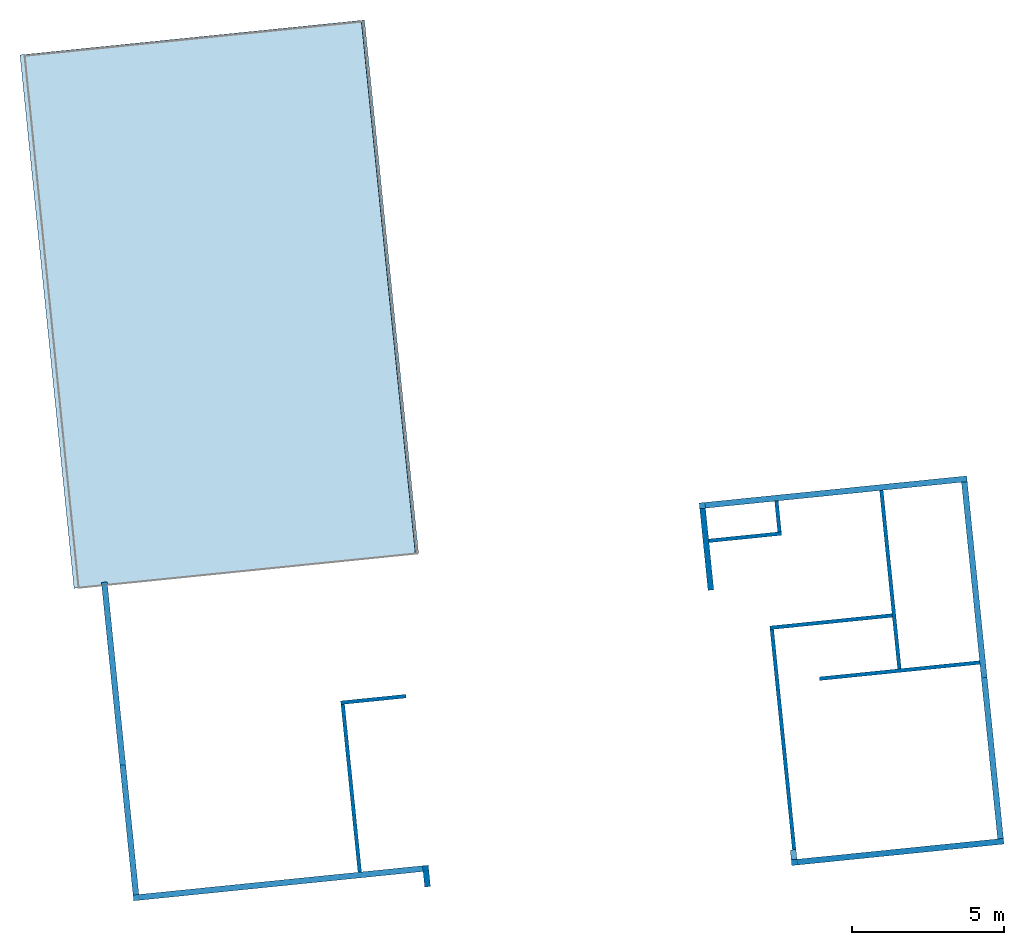
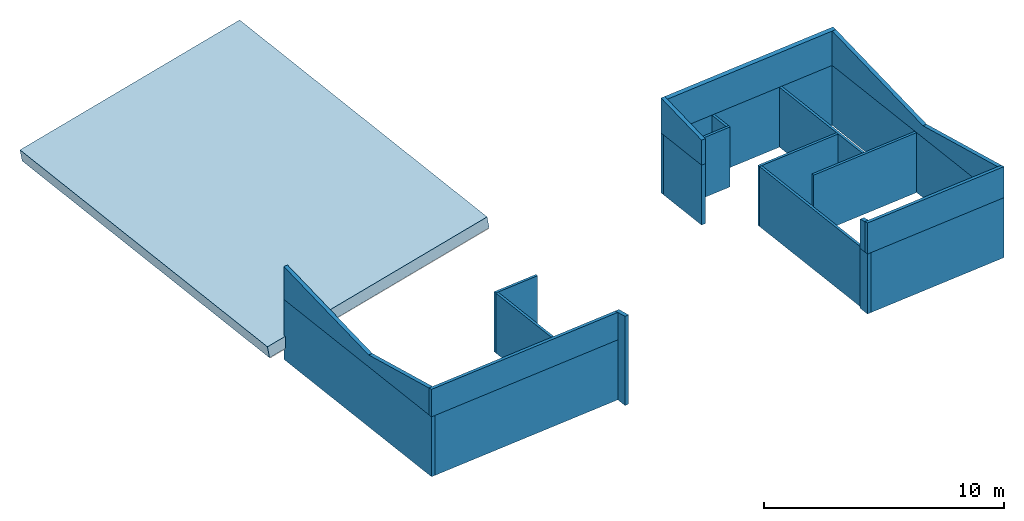
# One storey, part 1 of 2: 23 walls, 1 slab, 1 element without a shape of its own.
"""IFC2X3 building model written with IfcOpenShell, lengths in feet."""

from ifc_helpers import new_model, entity, si_unit, converted_unit, derived_unit, direction, frame, frame_2d, origin, place, context, subcontext, project, spatial, polyline, rectangle, extrude, clip, bounded_halfspace, material, layer, layer_set, layer_usage, type_object, element, aggregate, save


model = new_model("IFC2X3")

# Units and contexts
model_context = context("Model", 3, precision=0.0001, world=origin(), true_north=direction((0.100810849702482, 0.994905609885814)))
body_context = subcontext(model_context, "Body", "Model", "MODEL_VIEW")
ifc_project = project(units=[converted_unit("LENGTHUNIT", "FOOT", entity("IfcRatioMeasure", 0.3048), si_unit("LENGTHUNIT", "METRE"), dimensions=[1, 0, 0, 0, 0, 0, 0]), converted_unit("AREAUNIT", "SQUARE FOOT", entity("IfcRatioMeasure", 0.09290304), si_unit("AREAUNIT", "SQUARE_METRE"), dimensions=[2, 0, 0, 0, 0, 0, 0]), converted_unit("VOLUMEUNIT", "CUBIC FOOT", entity("IfcRatioMeasure", 0.028316846592), si_unit("VOLUMEUNIT", "CUBIC_METRE"), dimensions=[3, 0, 0, 0, 0, 0, 0]), converted_unit("PLANEANGLEUNIT", "DEGREE", entity("IfcRatioMeasure", 0.0174532925199433), si_unit("PLANEANGLEUNIT", "RADIAN"), dimensions=[0, 0, 0, 0, 0, 0, 0]), si_unit("MASSUNIT", "GRAM", prefix="KILO"), derived_unit("MASSDENSITYUNIT", [(si_unit("MASSUNIT", "GRAM", prefix="KILO"), 1), (si_unit("LENGTHUNIT", "METRE"), -3)]), si_unit("TIMEUNIT", "SECOND"), si_unit("FREQUENCYUNIT", "HERTZ"), si_unit("THERMODYNAMICTEMPERATUREUNIT", "DEGREE_CELSIUS"), derived_unit("THERMALTRANSMITTANCEUNIT", [(si_unit("MASSUNIT", "GRAM", prefix="KILO"), 1), (si_unit("THERMODYNAMICTEMPERATUREUNIT", "KELVIN"), -1), (si_unit("TIMEUNIT", "SECOND"), -3)]), derived_unit("VOLUMETRICFLOWRATEUNIT", [(si_unit("LENGTHUNIT", "METRE"), 3), (si_unit("TIMEUNIT", "SECOND"), -1)]), si_unit("ELECTRICCURRENTUNIT", "AMPERE"), si_unit("ELECTRICVOLTAGEUNIT", "VOLT"), si_unit("POWERUNIT", "WATT"), si_unit("FORCEUNIT", "NEWTON"), si_unit("ILLUMINANCEUNIT", "LUX"), si_unit("LUMINOUSFLUXUNIT", "LUMEN"), si_unit("LUMINOUSINTENSITYUNIT", "CANDELA"), derived_unit("USERDEFINED", [(si_unit("MASSUNIT", "GRAM", prefix="KILO"), -1), (si_unit("LENGTHUNIT", "METRE"), -2), (si_unit("TIMEUNIT", "SECOND"), 3), (si_unit("LUMINOUSFLUXUNIT", "LUMEN"), 1)]), derived_unit("LINEARVELOCITYUNIT", [(si_unit("LENGTHUNIT", "METRE"), 1), (si_unit("TIMEUNIT", "SECOND"), -1)]), si_unit("PRESSUREUNIT", "PASCAL"), derived_unit("USERDEFINED", [(si_unit("LENGTHUNIT", "METRE"), -2), (si_unit("MASSUNIT", "GRAM", prefix="KILO"), 1), (si_unit("TIMEUNIT", "SECOND"), -2)])], contexts=[model_context])

# Site, building, storey
site_placement = place(None, frame((124.447249452883, 13.3868691254093, 0.0), z_axis=(0.0, 0.0, 1.0), x_axis=(0.994905609885814, 0.100810849702482, 0.0)))
site = spatial("IfcSite", under=ifc_project, at=site_placement, CompositionType="ELEMENT")
building_placement = place(site_placement, origin())
building = spatial("IfcBuilding", under=site, at=building_placement, CompositionType="ELEMENT")
storey_placement = place(building_placement, frame((0.0, 0.0, 12.0)))
storey = spatial("IfcBuildingStorey", under=building, at=storey_placement, Name="Second Floor", CompositionType="ELEMENT", Elevation=12.0)

# Roof, slab
ifc_material_1 = material(Name="Default Roof")
roof_placement = place(storey_placement, origin())
roof = element("IfcRoof", 1, at=roof_placement, inside=storey, material=ifc_material_1, Name="Garage Roof Component:Garage Roof Component", ObjectType="Garage Roof Component:Garage Roof Component", ShapeType="NOTDEFINED")
slab_placement = place(storey_placement, origin())
slab = element("IfcSlab", 2, at=slab_placement, material=ifc_material_1, Name="Garage Roof Component:Garage Roof Component:1", ObjectType="Garage Roof Component:Garage Roof Component", PredefinedType="ROOF", context=body_context, shape_type="SweptSolid", body=[
    extrude(rectangle(XDim=2.00000000001789, YDim=37.5707846397741, at=frame_2d((-1.77635683940025e-15, -3.08642000845794e-14), x_axis=(0.0, 1.0))), frame((-14.8551381770312, -114.089477043415, 5.77919120324156), z_axis=(0.0, 1.0, 0.0), x_axis=(0.984807753012272, 0.0, 0.173648177666569)), (0.0, 0.0, 1.0), 57.8249956509803),
])
aggregate(roof, [slab])

# Walls
ifc_material_2 = material(Name="Stucco")
ifc_layer_1 = layer(ifc_material_2, 0.0729166666666667)
ifc_material_3 = material(Name="Plywood, Sheathing")
ifc_layer_2 = layer(ifc_material_3, 0.0416666666666667)
ifc_material_4 = material(Name="Softwood, Lumber")
ifc_layer_3 = layer(ifc_material_4, 0.458333333333333)
ifc_material_5 = material(Name="Gypsum Wall Board")
ifc_layer_4 = layer(ifc_material_5, 0.0520833333333333)
ifc_layer_set_1 = layer_set([ifc_layer_1, ifc_layer_2, ifc_layer_3, ifc_layer_4])
ifc_layer_usage_1 = layer_usage(ifc_layer_set_1, "AXIS2", "NEGATIVE", 0.3125)
wall_type_1 = type_object("IfcWallType", PredefinedType="STANDARD", material=ifc_layer_set_1)
wall_1_placement = place(storey_placement, frame((63.1587136453103, -112.353023059104, 0.0), z_axis=(0.0, 0.0, 1.0), x_axis=(0.0, -1.0, 0.0)))
element("IfcWallStandardCase", 3, at=wall_1_placement, inside=storey, type_object=wall_type_1, material=ifc_layer_usage_1, Name="Basic Wall:Exterior - Stucco (light) on Wood Stud", context=body_context, shape_type="SweptSolid", body=[
    extrude(rectangle(XDim=38.6614583333334, YDim=0.625, at=frame_2d((19.3307291666667, -9.99200722162641e-16), x_axis=(-1.0, 0.0))), origin(), (0.0, 0.0, 1.0), 10.0),
])
ifc_layer_usage_2 = layer_usage(ifc_layer_set_1, "AXIS2", "NEGATIVE", 0.3125)
wall_2_placement = place(storey_placement, frame((63.1587136453103, -112.353023059104, 10.0), z_axis=(0.0, 0.0, 1.0), x_axis=(0.0, -1.0, 0.0)))
element("IfcWallStandardCase", 4, at=wall_2_placement, inside=storey, type_object=wall_type_1, material=ifc_layer_usage_2, Name="Basic Wall:Exterior - Stucco (light) on Wood Stud", context=body_context, shape_type="Clipping", body=[
    clip(clip(extrude(rectangle(XDim=38.6614583333334, YDim=0.625, at=frame_2d((19.3307291666667, -9.99200722162641e-16), x_axis=(-1.0, 0.0))), origin(), (0.0, 0.0, 1.0), 5.72473740754003), bounded_halfspace(frame((21.2163190642322, -0.312499999999999, 1.98372792519705), z_axis=(0.174064214161642, 0.0, -0.984734303935985), x_axis=(0.0, -1.0, 0.0)), True, frame((21.2163190642322, -0.312499999999999, 1.98372792519705)), polyline([(0.0, 0.0), (17.4451392691012, 0.0), (17.4451392691012, 0.625), (0.0, 0.625), (0.0, 0.0)]))), bounded_halfspace(frame((0.0, -0.312499999999998, 5.72473740754003), z_axis=(-0.173648177666906, 0.0, -0.984807753012212), x_axis=(0.0, -1.0, 0.0)), True, frame((0.0, -0.312499999999998, 5.72473740754003)), polyline([(0.0, 0.0), (21.2163190642322, 0.0), (21.2163190642322, 0.624999999999998), (0.0, 0.625), (0.0, 0.0)]))),
])
ifc_layer_usage_3 = layer_usage(ifc_layer_set_1, "AXIS2", "NEGATIVE", 0.3125)
wall_3_placement = place(storey_placement, frame((-30.2162863546899, -148.264481392437, 0.0), z_axis=(0.0, 0.0, 1.0), x_axis=(0.0, 1.0, 0.0)))
element("IfcWallStandardCase", 5, at=wall_3_placement, inside=storey, type_object=wall_type_1, material=ifc_layer_usage_3, Name="Basic Wall:Exterior - Stucco (light) on Wood Stud", context=body_context, shape_type="SweptSolid", body=[
    extrude(rectangle(XDim=34.5104166666665, YDim=0.625, at=frame_2d((17.2552083333333, 0.0), x_axis=(-1.0, 0.0))), origin(), (0.0, 0.0, 1.0), 10.0),
])
ifc_layer_usage_4 = layer_usage(ifc_layer_set_1, "AXIS2", "NEGATIVE", 0.3125)
wall_4_placement = place(storey_placement, frame((-30.2162863546899, -147.639481392437, 10.0), z_axis=(0.0, 0.0, 1.0), x_axis=(0.0, 1.0, 0.0)))
element("IfcWallStandardCase", 6, at=wall_4_placement, inside=storey, type_object=wall_type_1, material=ifc_layer_usage_4, Name="Basic Wall:Exterior - Stucco (light) on Wood Stud", context=body_context, shape_type="Clipping", body=[
    clip(clip(extrude(rectangle(XDim=33.8854166666665, YDim=0.625, at=frame_2d((16.9427083333333, -3.60822483003176e-16), x_axis=(-1.0, 0.0))), origin(), (0.0, 0.0, 1.0), 5.47769596060954), bounded_halfspace(frame((0.0, -0.312499999999999, 4.47080258607907), z_axis=(-0.174064214161642, 0.0, -0.984734303935985), x_axis=(0.0, 1.0, 0.0)), True, frame((0.0, -0.312499999999999, 4.47080258607907)), polyline([(0.0, 0.0), (14.0701392691009, 0.0), (14.0701392691009, 0.625000000000006), (0.0, 0.625), (0.0, 0.0)]))), bounded_halfspace(frame((14.0701392691009, -0.312500000000001, 1.98372792519661), z_axis=(0.173648177666906, 0.0, -0.984807753012212), x_axis=(0.0, 1.0, 0.0)), True, frame((14.0701392691009, -0.312500000000001, 1.98372792519661)), polyline([(0.0, 0.0), (19.4194440642323, 0.0), (19.8152773975656, 0.0), (19.8152773975656, 0.625000000000001), (0.0, 0.625), (0.0, 0.0)]))),
])
ifc_layer_usage_5 = layer_usage(ifc_layer_set_1, "AXIS2", "NEGATIVE", 0.3125)
wall_5_placement = place(storey_placement, frame((1.15871364531007, -149.951981392437, 0.0), z_axis=(0.0, 0.0, 1.0), x_axis=(0.0, 1.0, 0.0)))
element("IfcWallStandardCase", 7, at=wall_5_placement, inside=storey, type_object=wall_type_1, material=ifc_layer_usage_5, Name="Basic Wall:Exterior - Stucco (light) on Wood Stud", context=body_context, shape_type="Clipping", body=[
    clip(extrude(rectangle(XDim=2.3125, YDim=0.625, at=frame_2d((1.15625, 5.55111512312578e-17), x_axis=(-1.0, 0.0))), origin(), (0.0, 0.0, 1.0), 14.8795661415276), bounded_halfspace(frame((0.0, -0.3125, 14.8795661415276), z_axis=(-0.174064214161642, 0.0, -0.984734303935985), x_axis=(0.0, 1.0, 0.0)), True, frame((0.0, -0.3125, 14.8795661415276)), polyline([(0.0, 0.0), (2.3125, 0.0), (2.3125, 0.625), (1.6875, 0.625), (0.0, 0.625), (0.0, 0.0)]))),
])
ifc_material_6 = material(Name="Stucco - Black")
ifc_layer_5 = layer(ifc_material_6, 0.0729166666666667)
ifc_layer_6 = layer(ifc_material_3, 0.0416666666666667)
ifc_layer_7 = layer(ifc_material_4, 0.458333333333333)
ifc_layer_8 = layer(ifc_material_5, 0.0520833333333333)
ifc_layer_set_2 = layer_set([ifc_layer_5, ifc_layer_6, ifc_layer_7, ifc_layer_8])
ifc_layer_usage_6 = layer_usage(ifc_layer_set_2, "AXIS2", "POSITIVE", -0.3125)
wall_type_2 = type_object("IfcWallType", PredefinedType="STANDARD", material=ifc_layer_set_2)
wall_6_placement = place(storey_placement, frame((40.4712136453103, -151.326981392437, 10.0)))
element("IfcWallStandardCase", 8, at=wall_6_placement, inside=storey, type_object=wall_type_2, material=ifc_layer_usage_6, Name="Basic Wall:Exterior - Stucco (dark) on Wood Stud", context=body_context, shape_type="Clipping", body=[
    clip(extrude(rectangle(XDim=22.9999999999999, YDim=0.625, at=frame_2d((11.5, 0.0), x_axis=(-1.0, 0.0))), origin(), (0.0, 0.0, 1.0), 5.17785306036855), bounded_halfspace(frame((0.0, -0.3125, 5.17785306036844), z_axis=(0.0, -0.174064214161642, -0.984734303935985), x_axis=(-1.0, 0.0, 0.0)), True, frame((0.0, -0.3125, 5.17785306036844)), polyline([(0.0, 0.0), (23.0, 0.0), (23.0, 0.625), (22.3749999999999, 0.625), (0.625000000000007, 0.625), (0.0, 0.625), (0.0, 0.0)]))),
])
ifc_layer_usage_7 = layer_usage(ifc_layer_set_2, "AXIS2", "NEGATIVE", 0.3125)
wall_7_placement = place(storey_placement, frame((40.7837136453103, -151.014481392437, 10.0), z_axis=(0.0, 0.0, 1.0), x_axis=(0.0, 1.0, 0.0)))
element("IfcWallStandardCase", 9, at=wall_7_placement, inside=storey, type_object=wall_type_2, material=ifc_layer_usage_7, Name="Basic Wall:Exterior - Stucco (dark) on Wood Stud", context=body_context, shape_type="Clipping", body=[
    clip(extrude(rectangle(XDim=1.06250000000006, YDim=0.625, at=frame_2d((0.531250000000028, 1.4432899320127e-15), x_axis=(-1.0, 0.0))), origin(), (0.0, 0.0, 1.0), 5.06737642376079), bounded_halfspace(frame((0.0, -0.312499999999997, 5.06737642376079), z_axis=(-0.174064214161642, 0.0, -0.984734303935985), x_axis=(0.0, 1.0, 0.0)), True, frame((0.0, -0.312499999999997, 5.06737642376079)), polyline([(0.0, 0.0), (1.06250000000006, 0.0), (1.06250000000006, 0.625000000000003), (0.0, 0.625), (0.0, 0.0)]))),
])
ifc_layer_usage_8 = layer_usage(ifc_layer_set_2, "AXIS2", "NEGATIVE", 0.3125)
wall_8_placement = place(storey_placement, frame((34.7837136453103, -121.201981392437, 10.0), z_axis=(0.0, 0.0, 1.0), x_axis=(0.0, 1.0, 0.0)))
element("IfcWallStandardCase", 10, at=wall_8_placement, inside=storey, type_object=wall_type_2, material=ifc_layer_usage_8, Name="Basic Wall:Exterior - Stucco (dark) on Wood Stud", context=body_context, shape_type="Clipping", body=[
    clip(extrude(rectangle(XDim=9.47395833333339, YDim=0.625, at=frame_2d((4.73697916666669, 9.99200722162641e-16), x_axis=(-1.0, 0.0))), origin(), (0.0, 0.0, 1.0), 5.83494177048269), bounded_halfspace(frame((0.0, -0.312500000000001, 4.16442730220844), z_axis=(0.173648177666906, 0.0, -0.984807753012212), x_axis=(0.0, 1.0, 0.0)), True, frame((0.0, -0.312500000000001, 4.16442730220844)), polyline([(0.0, 0.0), (8.84895833333339, 0.0), (9.47395833333339, 0.0), (9.47395833333339, 0.625000000000002), (0.0, 0.625), (0.0, 0.0)]))),
])
ifc_layer_usage_9 = layer_usage(ifc_layer_set_2, "AXIS2", "NEGATIVE", 0.3125)
wall_9_placement = place(storey_placement, frame((35.0962136453103, -112.040523059104, 10.0)))
element("IfcWallStandardCase", 11, at=wall_9_placement, inside=storey, type_object=wall_type_2, material=ifc_layer_usage_9, Name="Basic Wall:Exterior - Stucco (dark) on Wood Stud", context=body_context, shape_type="Clipping", body=[
    clip(extrude(rectangle(XDim=28.375, YDim=0.625, at=frame_2d((14.1875, -2.4980018054066e-16), x_axis=(-1.0, 0.0))), origin(), (0.0, 0.0, 1.0), 5.8349417704828), bounded_halfspace(frame((0.0, -0.3125, 5.72473740753991), z_axis=(0.0, 0.173648177666906, -0.984807753012212), x_axis=(-1.0, 0.0, 0.0)), True, frame((0.0, -0.3125, 5.72473740753991)), polyline([(0.0, 0.0), (27.75, 0.0), (28.375, 0.0), (28.375, 0.625), (0.0, 0.625), (0.0, 0.0)]))),
])
ifc_layer_usage_10 = layer_usage(ifc_layer_set_2, "AXIS2", "NEGATIVE", 0.3125)
wall_10_placement = place(storey_placement, frame((0.846213645310078, -147.951981392437, 10.0), z_axis=(0.0, 0.0, 1.0), x_axis=(-1.0, 0.0, 0.0)))
element("IfcWallStandardCase", 12, at=wall_10_placement, inside=storey, type_object=wall_type_2, material=ifc_layer_usage_10, Name="Basic Wall:Exterior - Stucco (dark) on Wood Stud", context=body_context, shape_type="Clipping", body=[
    clip(extrude(rectangle(XDim=31.375, YDim=0.625, at=frame_2d((15.6875, 0.0), x_axis=(-1.0, 0.0))), origin(), (0.0, 0.0, 1.0), 4.58127922268689), bounded_halfspace(frame((0.0, -0.3125, 4.47080258607923), z_axis=(0.0, 0.174064214161642, -0.984734303935985), x_axis=(1.0, 0.0, 0.0)), True, frame((0.0, -0.3125, 4.47080258607923)), polyline([(0.0, 0.0), (30.75, 0.0), (31.375, 0.0), (31.375, 0.625), (0.0, 0.625), (0.0, 0.0)]))),
])
ifc_layer_9 = layer(ifc_material_5, 0.0520833333333333)
ifc_layer_10 = layer(ifc_material_4, 0.291666666666667)
ifc_layer_11 = layer(ifc_material_5, 0.0520833333333333)
ifc_layer_set_3 = layer_set([ifc_layer_9, ifc_layer_10, ifc_layer_11])
ifc_layer_usage_11 = layer_usage(ifc_layer_set_3, "AXIS2", "NEGATIVE", 0.197916666666667)
wall_type_3 = type_object("IfcWallType", PredefinedType="STANDARD", material=ifc_layer_set_3)
wall_11_placement = place(storey_placement, frame((0.908713645310107, -129.264481392437, 0.0), z_axis=(0.0, 0.0, 1.0), x_axis=(-1.0, 0.0, 0.0)))
element("IfcWallStandardCase", 13, at=wall_11_placement, inside=storey, type_object=wall_type_3, material=ifc_layer_usage_11, context=body_context, shape_type="SweptSolid", body=[
    extrude(rectangle(XDim=7.06250000000001, YDim=0.395833333333314, at=frame_2d((3.53125000000001, 0.0), x_axis=(-1.0, 0.0))), origin(), (0.0, 0.0, 1.0), 10.0),
])
ifc_layer_usage_12 = layer_usage(ifc_layer_set_3, "AXIS2", "NEGATIVE", 0.197916666666667)
wall_12_placement = place(storey_placement, frame((-5.95586968802324, -129.462398059104, 0.0), z_axis=(0.0, 0.0, 1.0), x_axis=(0.0, -1.0, 0.0)))
element("IfcWallStandardCase", 14, at=wall_12_placement, inside=storey, type_object=wall_type_3, material=ifc_layer_usage_12, context=body_context, shape_type="SweptSolid", body=[
    extrude(rectangle(XDim=18.1770833333333, YDim=0.395833333333334, at=frame_2d((9.08854166666666, 0.0), x_axis=(-1.0, 0.0))), origin(), (0.0, 0.0, 1.0), 10.0),
])
ifc_layer_usage_13 = layer_usage(ifc_layer_set_3, "AXIS2", "NEGATIVE", 0.197916666666667)
wall_13_placement = place(storey_placement, frame((54.1587136453102, -112.353023059104, 0.0), z_axis=(0.0, 0.0, 1.0), x_axis=(0.0, -1.0, 0.0)))
element("IfcWallStandardCase", 15, at=wall_13_placement, inside=storey, type_object=wall_type_3, material=ifc_layer_usage_13, context=body_context, shape_type="SweptSolid", body=[
    extrude(rectangle(XDim=19.3385416666667, YDim=0.395833333333329, at=frame_2d((9.66927083333334, -8.04911692853238e-16), x_axis=(-1.0, 0.0))), origin(), (0.0, 0.0, 1.0), 10.0),
])
ifc_layer_usage_14 = layer_usage(ifc_layer_set_3, "AXIS2", "NEGATIVE", 0.197916666666667)
wall_14_placement = place(storey_placement, frame((53.9607969786436, -125.889481392437, 0.0), z_axis=(0.0, 0.0, 1.0), x_axis=(-1.0, 0.0, 0.0)))
element("IfcWallStandardCase", 16, at=wall_14_placement, inside=storey, type_object=wall_type_3, material=ifc_layer_usage_14, context=body_context, shape_type="SweptSolid", body=[
    extrude(rectangle(XDim=13.2604166666666, YDim=0.395833333333343, at=frame_2d((6.63020833333329, 0.0), x_axis=(-1.0, 0.0))), origin(), (0.0, 0.0, 1.0), 10.0),
])
ifc_layer_usage_15 = layer_usage(ifc_layer_set_3, "AXIS2", "NEGATIVE", 0.197916666666667)
wall_15_placement = place(storey_placement, frame((40.8982969786437, -126.087398059104, 0.0), z_axis=(0.0, 0.0, 1.0), x_axis=(0.0, -1.0, 0.0)))
element("IfcWallStandardCase", 17, at=wall_15_placement, inside=storey, type_object=wall_type_3, material=ifc_layer_usage_15, context=body_context, shape_type="SweptSolid", body=[
    extrude(rectangle(XDim=23.8645833333334, YDim=0.395833333333329, at=frame_2d((11.9322916666667, -3.7470027081099e-16), x_axis=(-1.0, 0.0))), origin(), (0.0, 0.0, 1.0), 10.0),
])
ifc_layer_usage_16 = layer_usage(ifc_layer_set_3, "AXIS2", "NEGATIVE", 0.197916666666667)
wall_16_placement = place(storey_placement, frame((35.0962136453103, -115.889481392437, 0.0)))
element("IfcWallStandardCase", 18, at=wall_16_placement, inside=storey, type_object=wall_type_3, material=ifc_layer_usage_16, context=body_context, shape_type="SweptSolid", body=[
    extrude(rectangle(XDim=7.88541666666667, YDim=0.395833333333343, at=frame_2d((3.94270833333334, 6.93889390390723e-17), x_axis=(-1.0, 0.0))), origin(), (0.0, 0.0, 1.0), 10.0),
])
ifc_layer_usage_17 = layer_usage(ifc_layer_set_3, "AXIS2", "NEGATIVE", 0.197916666666667)
wall_17_placement = place(storey_placement, frame((42.7837136453103, -115.69156472577, 0.0), z_axis=(0.0, 0.0, 1.0), x_axis=(0.0, 1.0, 0.0)))
element("IfcWallStandardCase", 19, at=wall_17_placement, inside=storey, type_object=wall_type_3, material=ifc_layer_usage_17, context=body_context, shape_type="SweptSolid", body=[
    extrude(rectangle(XDim=3.33854166666664, YDim=0.395833333333329, at=frame_2d((1.66927083333332, -1.66533453693773e-16), x_axis=(-1.0, 0.0))), origin(), (0.0, 0.0, 1.0), 10.0),
])
ifc_layer_usage_18 = layer_usage(ifc_layer_set_3, "AXIS2", "NEGATIVE", 0.197916666666667)
wall_18_placement = place(storey_placement, frame((45.4816303119769, -131.889481392437, 0.0)))
element("IfcWallStandardCase", 20, at=wall_18_placement, inside=storey, type_object=wall_type_3, material=ifc_layer_usage_18, context=body_context, shape_type="SweptSolid", body=[
    extrude(rectangle(XDim=17.3645833333334, YDim=0.395833333333314, at=frame_2d((8.68229166666668, -4.02455846426619e-16), x_axis=(-1.0, 0.0))), origin(), (0.0, 0.0, 1.0), 10.0),
])
ifc_material_7 = material(Name="HAF Longboard")
ifc_layer_12 = layer(ifc_material_7, 0.0729166666666667)
ifc_layer_13 = layer(ifc_material_3, 0.0416666666666667)
ifc_layer_14 = layer(ifc_material_4, 0.458333333333333)
ifc_layer_15 = layer(ifc_material_5, 0.0520833333333333)
ifc_layer_set_4 = layer_set([ifc_layer_12, ifc_layer_13, ifc_layer_14, ifc_layer_15], Name="Basic Wall:HAF Exterior - Longboard on Wood Stud")
ifc_layer_usage_19 = layer_usage(ifc_layer_set_4, "AXIS2", "NEGATIVE", 0.3125)
wall_type_4 = type_object("IfcWallType", Name="Basic Wall:HAF Exterior - Longboard on Wood Stud", PredefinedType="STANDARD", material=ifc_layer_set_4)
wall_19_placement = place(storey_placement, frame((34.4712136453103, -112.040523059104, 0.0)))
element("IfcWallStandardCase", 21, at=wall_19_placement, inside=storey, type_object=wall_type_4, material=ifc_layer_usage_19, Name="Basic Wall:Exterior - Longboard on Wood Stud", ObjectType="Basic Wall:HAF Exterior - Longboard on Wood Stud", context=body_context, shape_type="Clipping", body=[
    clip(extrude(rectangle(XDim=29.0, YDim=0.625, at=frame_2d((14.5, 8.32667268468867e-16), x_axis=(-1.0, 0.0))), origin(), (0.0, 0.0, 1.0), 10.0), bounded_halfspace(frame((0.0, -0.3125, 10.0), z_axis=(0.0, 0.0, -1.0), x_axis=(0.0, 1.0, 0.0)), True, frame((0.0, -0.3125, 10.0)), polyline([(0.0, 0.0), (0.625, 0.0), (8.11458333333334, 0.0), (8.51041666666667, 0.0), (19.4895833333333, 0.0), (19.8854166666666, 0.0), (28.375, 0.0), (29.0, 0.0), (29.0, 0.625000000000014), (0.625, 0.625000000000014), (0.0, 0.625), (0.0, 0.0)]))),
])
ifc_layer_usage_20 = layer_usage(ifc_layer_set_4, "AXIS2", "POSITIVE", -0.3125)
wall_20_placement = place(storey_placement, frame((41.0962136453103, -151.326981392437, 0.0)))
element("IfcWallStandardCase", 22, at=wall_20_placement, inside=storey, type_object=wall_type_4, material=ifc_layer_usage_20, Name="Basic Wall:Exterior - Longboard on Wood Stud", ObjectType="Basic Wall:HAF Exterior - Longboard on Wood Stud", context=body_context, shape_type="Clipping", body=[
    clip(extrude(rectangle(XDim=22.3749999999999, YDim=0.625, at=frame_2d((11.1875, 0.0), x_axis=(-1.0, 0.0))), origin(), (0.0, 0.0, 1.0), 10.0), bounded_halfspace(frame((0.0, -0.3125, 10.0), z_axis=(0.0, 0.0, -1.0), x_axis=(0.0, 1.0, 0.0)), True, frame((0.0, -0.3125, 10.0)), polyline([(0.0, 0.0), (22.3749999999999, 0.0), (22.3749999999999, 0.625), (21.7499999999999, 0.625), (0.0, 0.625), (0.0, 0.0)]))),
])
ifc_layer_usage_21 = layer_usage(ifc_layer_set_4, "AXIS2", "NEGATIVE", 0.3125)
wall_21_placement = place(storey_placement, frame((40.7837136453103, -151.639481392437, 0.0), z_axis=(0.0, 0.0, 1.0), x_axis=(0.0, 1.0, 0.0)))
element("IfcWallStandardCase", 23, at=wall_21_placement, inside=storey, type_object=wall_type_4, material=ifc_layer_usage_21, Name="Basic Wall:Exterior - Longboard on Wood Stud", ObjectType="Basic Wall:HAF Exterior - Longboard on Wood Stud", context=body_context, shape_type="Clipping", body=[
    clip(extrude(rectangle(XDim=1.68750000000006, YDim=0.625, at=frame_2d((0.843750000000028, -1.27675647831893e-15), x_axis=(-1.0, 0.0))), origin(), (0.0, 0.0, 1.0), 10.0), bounded_halfspace(frame((0.0, -0.312499999999998, 10.0), z_axis=(0.0, 0.0, -1.0), x_axis=(0.0, 1.0, 0.0)), True, frame((0.0, -0.312499999999998, 10.0)), polyline([(0.0, 0.0), (0.625, 0.0), (1.68750000000006, 0.0), (1.68750000000006, 0.624999999999997), (0.625, 0.624999999999995), (0.0, 0.625), (0.0, 0.0)]))),
])
ifc_layer_usage_22 = layer_usage(ifc_layer_set_4, "AXIS2", "NEGATIVE", 0.3125)
wall_22_placement = place(storey_placement, frame((34.7837136453103, -121.201981392437, 0.0), z_axis=(0.0, 0.0, 1.0), x_axis=(0.0, 1.0, 0.0)))
element("IfcWallStandardCase", 24, at=wall_22_placement, inside=storey, type_object=wall_type_4, material=ifc_layer_usage_22, Name="Basic Wall:Exterior - Longboard on Wood Stud", ObjectType="Basic Wall:HAF Exterior - Longboard on Wood Stud", context=body_context, shape_type="Clipping", body=[
    clip(extrude(rectangle(XDim=8.84895833333339, YDim=0.625, at=frame_2d((4.42447916666669, 4.71844785465692e-16), x_axis=(-1.0, 0.0))), origin(), (0.0, 0.0, 1.0), 10.0), bounded_halfspace(frame((0.0, -0.312500000000001, 10.0), z_axis=(0.0, 0.0, -1.0), x_axis=(0.0, 1.0, 0.0)), True, frame((0.0, -0.312500000000001, 10.0)), polyline([(0.0, 0.0), (5.11458333333341, 0.0), (5.51041666666674, 0.0), (8.84895833333339, 0.0), (8.84895833333339, 0.625000000000001), (0.0, 0.625), (0.0, 0.0)]))),
])
ifc_layer_usage_23 = layer_usage(ifc_layer_set_4, "AXIS2", "NEGATIVE", 0.3125)
wall_23_placement = place(storey_placement, frame((1.47121364531008, -147.951981392437, 0.0), z_axis=(0.0, 0.0, 1.0), x_axis=(-1.0, 0.0, 0.0)))
element("IfcWallStandardCase", 25, at=wall_23_placement, inside=storey, type_object=wall_type_4, material=ifc_layer_usage_23, Name="Basic Wall:Exterior - Longboard on Wood Stud", ObjectType="Basic Wall:HAF Exterior - Longboard on Wood Stud", context=body_context, shape_type="Clipping", body=[
    clip(extrude(rectangle(XDim=31.375, YDim=0.625, at=frame_2d((15.6875, 0.0), x_axis=(-1.0, 0.0))), origin(), (0.0, 0.0, 1.0), 10.0), bounded_halfspace(frame((0.0, -0.3125, 10.0), z_axis=(0.0, 0.0, -1.0), x_axis=(0.0, 1.0, 0.0)), True, frame((0.0, -0.3125, 10.0)), polyline([(0.0, 0.0), (0.562499999999999, 0.0), (0.625, 0.0), (7.22916666666665, 0.0), (7.62499999999999, 0.0), (31.375, 0.0), (31.375, 0.625), (0.624999999999996, 0.625), (0.0, 0.625), (0.0, 0.0)]))),
])

save(model, "model.ifc")
